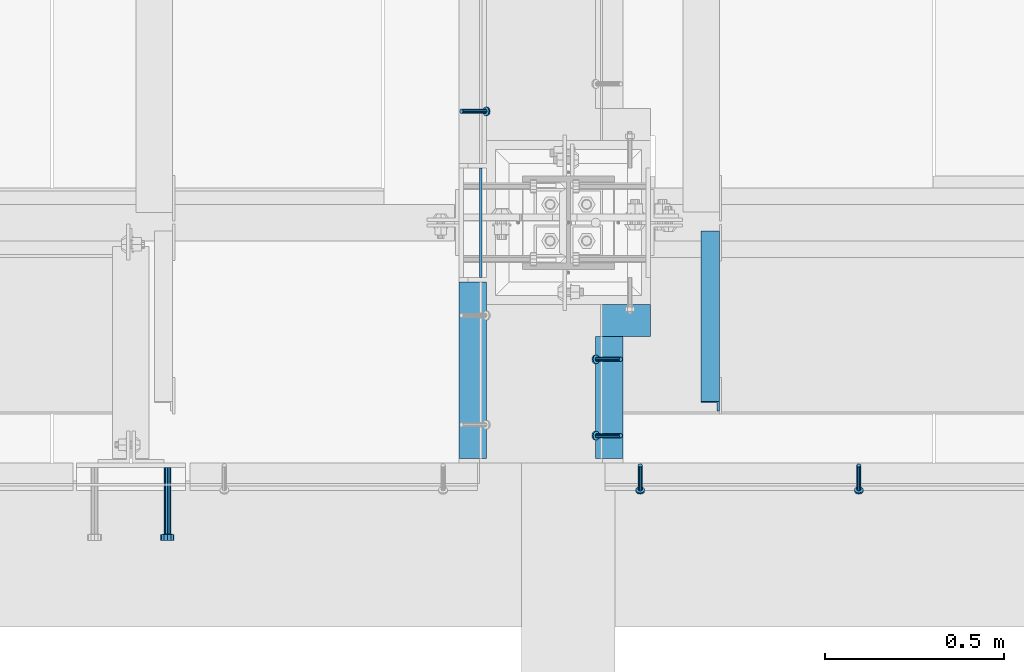
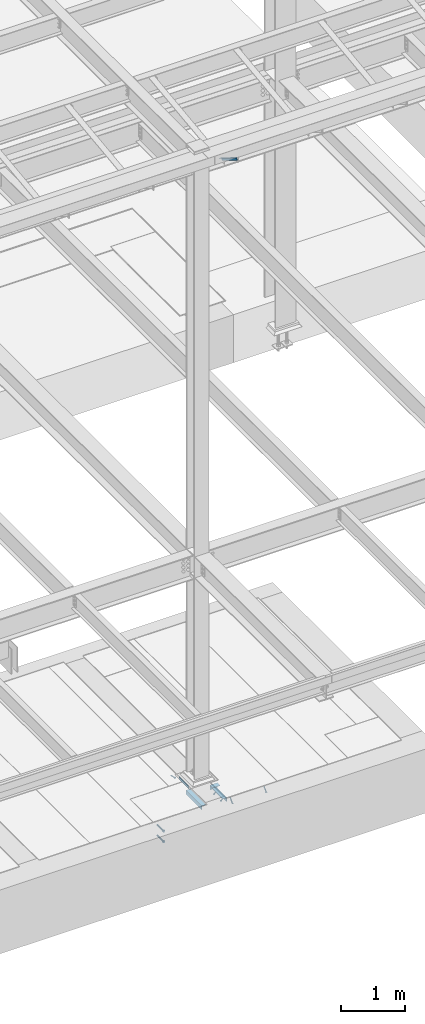
# One storey, part 2050 of 3843: 6 beams, 6 members, 8 elements without a shape of their own.
"""IFC2X3 building model written with IfcOpenShell, lengths in millimetres."""

from ifc_helpers import new_model, si_unit, frame, origin_with_axes, place, context, subcontext, project, spatial, faceted_brep, material, type_object, element, aggregate, save


model = new_model("IFC2X3")

# Units and contexts
model_context = context("Model", 3, precision=1e-05, world=origin_with_axes())
body_context = subcontext(model_context, "Body", "Model", "MODEL_VIEW")
ifc_project = project(units=[si_unit("LENGTHUNIT", "METRE", prefix="MILLI"), si_unit("AREAUNIT", "SQUARE_METRE"), si_unit("VOLUMEUNIT", "CUBIC_METRE"), si_unit("MASSUNIT", "GRAM", prefix="KILO"), si_unit("TIMEUNIT", "SECOND"), si_unit("PLANEANGLEUNIT", "RADIAN"), si_unit("SOLIDANGLEUNIT", "STERADIAN"), si_unit("THERMODYNAMICTEMPERATUREUNIT", "DEGREE_CELSIUS"), si_unit("LUMINOUSINTENSITYUNIT", "LUMEN")], contexts=[model_context])

# Site, building, storey
site_placement = place(None, origin_with_axes())
site = spatial("IfcSite", under=ifc_project, at=site_placement, CompositionType="ELEMENT")
building_placement = place(site_placement, origin_with_axes())
building = spatial("IfcBuilding", under=site, at=building_placement, Name="Undefined", CompositionType="ELEMENT")
storey_placement = place(building_placement, origin_with_axes())
storey = spatial("IfcBuildingStorey", under=building, at=storey_placement, Name="Undefined", CompositionType="ELEMENT", Elevation=0.0)

# Assembly, beam
assembly_1_placement = place(storey_placement, origin_with_axes())
assembly_1 = element("IfcElementAssembly", 1, at=assembly_1_placement, inside=storey, Name="EMBED PLATE", AssemblyPlace="NOTDEFINED", PredefinedType="RIGID_FRAME")
ifc_material_1 = material(Name="STEEL/A36")
beam_type_1 = type_object("IfcBeamType", PredefinedType="NOTDEFINED")
beam_1_placement = place(assembly_1_placement, frame((62391.9249969482, 15151.1, 30454.6), z_axis=(0.0, 0.0, 1.0), x_axis=(0.0, -1.0, 0.0)))
beam_1 = element("IfcBeam", 2, at=beam_1_placement, type_object=beam_type_1, material=ifc_material_1, Name="PLATE", context=body_context, shape_type="Brep", body=[
    faceted_brep([(0.0, 3.17499999999927, -25.4000000000015), (0.0, 3.17499999999927, 25.4000000000015), (304.800000000003, 3.17500000000291, 25.4000000000015), (304.800000000003, 3.17500000000291, -25.4000000000015), (0.0, -3.17499999999927, 25.4000000000015), (304.800000000003, -3.17500000000291, 25.4000000000015), (0.0, -3.17499999999927, -25.4000000000015), (304.800000000003, -3.17500000000291, -25.4000000000015)], [[[0, 1, 2, 3]], [[1, 4, 5, 2]], [[4, 6, 7, 5]], [[6, 0, 3, 7]], [[5, 7, 3, 2]], [[6, 4, 1, 0]]]),
])
aggregate(assembly_1, [beam_1])

# Assembly, members
assembly_2_placement = place(storey_placement, origin_with_axes())
assembly_2 = element("IfcElementAssembly", 3, at=assembly_2_placement, inside=storey, Name="ANGLE", AssemblyPlace="NOTDEFINED", PredefinedType="RIGID_FRAME")
ifc_material_2 = material(Name="STEEL/A108")
member_type_1 = type_object("IfcMemberType", PredefinedType="NOTDEFINED")
member_1_placement = place(assembly_2_placement, frame((62782.4499993064, 14617.7000062051, 30422.8500045777), z_axis=(0.0, -1.0, 0.0), x_axis=(-0.707106781186548, 0.0, -0.707106781186548)))
member_1 = element("IfcMember", 4, at=member_1_placement, type_object=member_type_1, material=ifc_material_2, Name="HEADED STUD ANCHOR", context=body_context, shape_type="Brep", body=[
    faceted_brep([(7.27595761418343e-12, -3.18000006675175, 5.5), (0.0, -5.49999999998363, 3.1800000667572), (94.4879985803855, -5.50000000011278, 3.1800000667572), (94.4879985803782, -3.18000006687362, 5.5), (0.0, -6.3499999046162, 0.0), (94.4879985803855, -6.34999990474535, 0.0), (0.0, -5.49999999998363, -3.1800000667572), (94.4879985803855, -5.50000000011278, -3.1800000667572), (7.27595761418343e-12, -3.18000006675175, -5.5), (94.4879985803782, -3.18000006687362, -5.5), (7.27595761418343e-12, -1.81898940354586e-12, -6.34999990463257), (94.4879985803782, -1.20053300634027e-10, -6.34999990463257), (0.0, 3.18000006675175, -5.5), (94.4879985803709, 3.18000006663351, -5.5), (7.27595761418343e-12, 5.49999999998363, -3.1800000667572), (94.4879985803709, 5.49999999987267, -3.1800000667572), (7.27595761418343e-12, 6.3499999046162, 0.0), (94.4879985803673, 6.34999990450706, 0.0), (7.27595761418343e-12, 5.49999999998363, 3.1800000667572), (94.4879985803709, 5.49999999987267, 3.1800000667572), (0.0, 3.18000006675175, 5.5), (94.4879985803709, 3.18000006663351, 5.5), (7.27595761418343e-12, -1.81898940354586e-12, 6.34999990463257), (94.4879985803782, -1.20053300634027e-10, 6.34999990463257), (96.5199985498621, -10.9899997712273, 6.34999990463257), (96.5199985498548, -6.34000015270249, 10.9899997711182), (96.5199985498621, -12.6999998093743, 0.0), (96.5199985498621, -10.9899997712273, -6.34999990463257), (96.5199985498548, -6.34000015270249, -10.9899997711182), (96.5199985498475, -1.21872290037572e-10, -12.6899995803833), (96.5199985498402, 6.34000015245874, -10.9899997711182), (96.519998549833, 10.9899997709817, -6.34999990463257), (96.519998549833, 12.6999998091305, 0.0), (96.519998549833, 10.9899997709817, 6.34999990463257), (96.5199985498402, 6.34000015245874, 10.9899997711182), (96.5199985498475, -1.21872290037572e-10, 12.6899995803833), (101.599998473539, -10.9899997712328, 6.34999990463257), (101.599998473532, -6.34000015270976, 10.9899997711182), (101.599998473539, -12.6999998093797, 0.0), (101.599998473539, -10.9899997712328, -6.34999990463257), (101.599998473532, -6.34000015270976, -10.9899997711182), (101.599998473524, -1.29148247651756e-10, -12.6899995803833), (101.599998473517, 6.34000015245329, -10.9899997711182), (101.59999847351, 10.9899997709763, -6.34999990463257), (101.599998473503, 12.6999998091196, 0.0), (101.59999847351, 10.9899997709763, 6.34999990463257), (101.599998473517, 6.34000015245329, 10.9899997711182), (101.599998473524, -1.29148247651756e-10, 12.6899995803833)], [[[0, 1, 2, 3]], [[1, 4, 5, 2]], [[4, 6, 7, 5]], [[6, 8, 9, 7]], [[8, 10, 11, 9]], [[10, 12, 13, 11]], [[12, 14, 15, 13]], [[14, 16, 17, 15]], [[16, 18, 19, 17]], [[18, 20, 21, 19]], [[20, 22, 23, 21]], [[22, 0, 3, 23]], [[22, 20, 18, 16, 14, 12, 10, 8, 6, 4, 1, 0]], [[3, 2, 24, 25]], [[2, 5, 26, 24]], [[5, 7, 27, 26]], [[7, 9, 28, 27]], [[9, 11, 29, 28]], [[11, 13, 30, 29]], [[13, 15, 31, 30]], [[15, 17, 32, 31]], [[17, 19, 33, 32]], [[19, 21, 34, 33]], [[21, 23, 35, 34]], [[23, 3, 25, 35]], [[25, 24, 36, 37]], [[24, 26, 38, 36]], [[26, 27, 39, 38]], [[27, 28, 40, 39]], [[28, 29, 41, 40]], [[29, 30, 42, 41]], [[30, 31, 43, 42]], [[31, 32, 44, 43]], [[32, 33, 45, 44]], [[33, 34, 46, 45]], [[34, 35, 47, 46]], [[35, 25, 37, 47]], [[38, 39, 40, 41, 42, 43, 44, 45, 46, 47, 37, 36]]]),
])
member_2_placement = place(assembly_2_placement, frame((62782.4499959028, 14404.9750001016, 30422.8500045777), z_axis=(0.0, -1.0, 0.0), x_axis=(-0.707106781186548, 0.0, -0.707106781186548)))
member_2 = element("IfcMember", 5, at=member_2_placement, type_object=member_type_1, material=ifc_material_2, Name="HEADED STUD ANCHOR", context=body_context, shape_type="Brep", body=[
    faceted_brep([(7.27595761418343e-12, -3.18000006675175, 5.5), (0.0, -5.49999999998363, 3.1800000667572), (94.4879985803855, -5.50000000011278, 3.1800000667572), (94.4879985803782, -3.18000006687362, 5.5), (0.0, -6.3499999046162, 0.0), (94.4879985803855, -6.34999990474535, 0.0), (0.0, -5.49999999998363, -3.1800000667572), (94.4879985803855, -5.50000000011278, -3.1800000667572), (7.27595761418343e-12, -3.18000006675175, -5.5), (94.4879985803782, -3.18000006687362, -5.5), (7.27595761418343e-12, -1.81898940354586e-12, -6.34999990463257), (94.4879985803782, -1.20053300634027e-10, -6.34999990463257), (0.0, 3.18000006675175, -5.5), (94.4879985803709, 3.18000006663351, -5.5), (7.27595761418343e-12, 5.49999999998363, -3.1800000667572), (94.4879985803709, 5.49999999987267, -3.1800000667572), (7.27595761418343e-12, 6.3499999046162, 0.0), (94.4879985803673, 6.34999990450706, 0.0), (7.27595761418343e-12, 5.49999999998363, 3.1800000667572), (94.4879985803709, 5.49999999987267, 3.1800000667572), (0.0, 3.18000006675175, 5.5), (94.4879985803709, 3.18000006663351, 5.5), (7.27595761418343e-12, -1.81898940354586e-12, 6.34999990463257), (94.4879985803782, -1.20053300634027e-10, 6.34999990463257), (96.5199985498621, -10.9899997712273, 6.34999990463257), (96.5199985498548, -6.34000015270249, 10.9899997711182), (96.5199985498621, -12.6999998093743, 0.0), (96.5199985498621, -10.9899997712273, -6.34999990463257), (96.5199985498548, -6.34000015270249, -10.9899997711182), (96.5199985498475, -1.21872290037572e-10, -12.6899995803833), (96.5199985498402, 6.34000015245874, -10.9899997711182), (96.519998549833, 10.9899997709817, -6.34999990463257), (96.519998549833, 12.6999998091305, 0.0), (96.519998549833, 10.9899997709817, 6.34999990463257), (96.5199985498402, 6.34000015245874, 10.9899997711182), (96.5199985498475, -1.21872290037572e-10, 12.6899995803833), (101.599998473539, -10.9899997712328, 6.34999990463257), (101.599998473532, -6.34000015270976, 10.9899997711182), (101.599998473539, -12.6999998093797, 0.0), (101.599998473539, -10.9899997712328, -6.34999990463257), (101.599998473532, -6.34000015270976, -10.9899997711182), (101.599998473524, -1.29148247651756e-10, -12.6899995803833), (101.599998473517, 6.34000015245329, -10.9899997711182), (101.59999847351, 10.9899997709763, -6.34999990463257), (101.599998473503, 12.6999998091196, 0.0), (101.59999847351, 10.9899997709763, 6.34999990463257), (101.599998473517, 6.34000015245329, 10.9899997711182), (101.599998473524, -1.29148247651756e-10, 12.6899995803833)], [[[0, 1, 2, 3]], [[1, 4, 5, 2]], [[4, 6, 7, 5]], [[6, 8, 9, 7]], [[8, 10, 11, 9]], [[10, 12, 13, 11]], [[12, 14, 15, 13]], [[14, 16, 17, 15]], [[16, 18, 19, 17]], [[18, 20, 21, 19]], [[20, 22, 23, 21]], [[22, 0, 3, 23]], [[22, 20, 18, 16, 14, 12, 10, 8, 6, 4, 1, 0]], [[3, 2, 24, 25]], [[2, 5, 26, 24]], [[5, 7, 27, 26]], [[7, 9, 28, 27]], [[9, 11, 29, 28]], [[11, 13, 30, 29]], [[13, 15, 31, 30]], [[15, 17, 32, 31]], [[17, 19, 33, 32]], [[19, 21, 34, 33]], [[21, 23, 35, 34]], [[23, 3, 25, 35]], [[25, 24, 36, 37]], [[24, 26, 38, 36]], [[26, 27, 39, 38]], [[27, 28, 40, 39]], [[28, 29, 41, 40]], [[29, 30, 42, 41]], [[30, 31, 43, 42]], [[31, 32, 44, 43]], [[32, 33, 45, 44]], [[33, 34, 46, 45]], [[34, 35, 47, 46]], [[35, 25, 37, 47]], [[38, 39, 40, 41, 42, 43, 44, 45, 46, 47, 37, 36]]]),
])

# Assembly, member
assembly_3_placement = place(storey_placement, origin_with_axes())
assembly_3 = element("IfcElementAssembly", 6, at=assembly_3_placement, inside=storey, Name="ANGLE", AssemblyPlace="NOTDEFINED", PredefinedType="RIGID_FRAME")
member_3_placement = place(assembly_3_placement, frame((62337.9500063455, 15309.056027729, 30422.8500045777), z_axis=(0.0, 1.0, 0.0), x_axis=(0.707106781186548, 0.0, -0.707106781186548)))
member_3 = element("IfcMember", 7, at=member_3_placement, type_object=member_type_1, material=ifc_material_2, Name="HEADED STUD ANCHOR", context=body_context, shape_type="Brep", body=[
    faceted_brep([(7.27595761418343e-12, -3.18000006675175, 5.5), (0.0, -5.49999999998363, 3.1800000667572), (94.4879985803855, -5.50000000011278, 3.1800000667572), (94.4879985803782, -3.18000006687362, 5.5), (0.0, -6.3499999046162, 0.0), (94.4879985803855, -6.34999990474535, 0.0), (0.0, -5.49999999998363, -3.1800000667572), (94.4879985803855, -5.50000000011278, -3.1800000667572), (7.27595761418343e-12, -3.18000006675175, -5.5), (94.4879985803782, -3.18000006687362, -5.5), (7.27595761418343e-12, -1.81898940354586e-12, -6.34999990463257), (94.4879985803782, -1.20053300634027e-10, -6.34999990463257), (0.0, 3.18000006675175, -5.5), (94.4879985803709, 3.18000006663351, -5.5), (7.27595761418343e-12, 5.49999999998363, -3.1800000667572), (94.4879985803709, 5.49999999987267, -3.1800000667572), (7.27595761418343e-12, 6.3499999046162, 0.0), (94.4879985803673, 6.34999990450706, 0.0), (7.27595761418343e-12, 5.49999999998363, 3.1800000667572), (94.4879985803709, 5.49999999987267, 3.1800000667572), (0.0, 3.18000006675175, 5.5), (94.4879985803709, 3.18000006663351, 5.5), (7.27595761418343e-12, -1.81898940354586e-12, 6.34999990463257), (94.4879985803782, -1.20053300634027e-10, 6.34999990463257), (96.5199985498621, -10.9899997712273, 6.34999990463257), (96.5199985498548, -6.34000015270249, 10.9899997711182), (96.5199985498621, -12.6999998093743, 0.0), (96.5199985498621, -10.9899997712273, -6.34999990463257), (96.5199985498548, -6.34000015270249, -10.9899997711182), (96.5199985498475, -1.21872290037572e-10, -12.6899995803833), (96.5199985498402, 6.34000015245874, -10.9899997711182), (96.519998549833, 10.9899997709817, -6.34999990463257), (96.519998549833, 12.6999998091305, 0.0), (96.519998549833, 10.9899997709817, 6.34999990463257), (96.5199985498402, 6.34000015245874, 10.9899997711182), (96.5199985498475, -1.21872290037572e-10, 12.6899995803833), (101.599998473539, -10.9899997712328, 6.34999990463257), (101.599998473532, -6.34000015270976, 10.9899997711182), (101.599998473539, -12.6999998093797, 0.0), (101.599998473539, -10.9899997712328, -6.34999990463257), (101.599998473532, -6.34000015270976, -10.9899997711182), (101.599998473524, -1.29148247651756e-10, -12.6899995803833), (101.599998473517, 6.34000015245329, -10.9899997711182), (101.59999847351, 10.9899997709763, -6.34999990463257), (101.599998473503, 12.6999998091196, 0.0), (101.59999847351, 10.9899997709763, 6.34999990463257), (101.599998473517, 6.34000015245329, 10.9899997711182), (101.599998473524, -1.29148247651756e-10, 12.6899995803833)], [[[0, 1, 2, 3]], [[1, 4, 5, 2]], [[4, 6, 7, 5]], [[6, 8, 9, 7]], [[8, 10, 11, 9]], [[10, 12, 13, 11]], [[12, 14, 15, 13]], [[14, 16, 17, 15]], [[16, 18, 19, 17]], [[18, 20, 21, 19]], [[20, 22, 23, 21]], [[22, 0, 3, 23]], [[22, 20, 18, 16, 14, 12, 10, 8, 6, 4, 1, 0]], [[3, 2, 24, 25]], [[2, 5, 26, 24]], [[5, 7, 27, 26]], [[7, 9, 28, 27]], [[9, 11, 29, 28]], [[11, 13, 30, 29]], [[13, 15, 31, 30]], [[15, 17, 32, 31]], [[17, 19, 33, 32]], [[19, 21, 34, 33]], [[21, 23, 35, 34]], [[23, 3, 25, 35]], [[25, 24, 36, 37]], [[24, 26, 38, 36]], [[26, 27, 39, 38]], [[27, 28, 40, 39]], [[28, 29, 41, 40]], [[29, 30, 42, 41]], [[30, 31, 43, 42]], [[31, 32, 44, 43]], [[32, 33, 45, 44]], [[33, 34, 46, 45]], [[34, 35, 47, 46]], [[35, 25, 37, 47]], [[38, 39, 40, 41, 42, 43, 44, 45, 46, 47, 37, 36]]]),
])
aggregate(assembly_3, [member_3])

# Assembly, members
assembly_4_placement = place(storey_placement, origin_with_axes())
assembly_4 = element("IfcElementAssembly", 8, at=assembly_4_placement, inside=storey, Name="ANGLE", AssemblyPlace="NOTDEFINED", PredefinedType="RIGID_FRAME")
member_4_placement = place(assembly_4_placement, frame((63446.0249989808, 14322.4249538032, 30422.8500024177), z_axis=(1.0, 0.0, 0.0), x_axis=(0.0, -0.707106781186548, -0.707106781186548)))
member_4 = element("IfcMember", 9, at=member_4_placement, type_object=member_type_1, material=ifc_material_2, Name="HEADED STUD ANCHOR", context=body_context, shape_type="Brep", body=[
    faceted_brep([(7.27595761418343e-12, -3.18000006675175, 5.5), (0.0, -5.49999999998363, 3.1800000667572), (94.4879985803855, -5.50000000011278, 3.1800000667572), (94.4879985803782, -3.18000006687362, 5.5), (0.0, -6.3499999046162, 0.0), (94.4879985803855, -6.34999990474535, 0.0), (0.0, -5.49999999998363, -3.1800000667572), (94.4879985803855, -5.50000000011278, -3.1800000667572), (7.27595761418343e-12, -3.18000006675175, -5.5), (94.4879985803782, -3.18000006687362, -5.5), (7.27595761418343e-12, -1.81898940354586e-12, -6.34999990463257), (94.4879985803782, -1.20053300634027e-10, -6.34999990463257), (0.0, 3.18000006675175, -5.5), (94.4879985803709, 3.18000006663351, -5.5), (7.27595761418343e-12, 5.49999999998363, -3.1800000667572), (94.4879985803709, 5.49999999987267, -3.1800000667572), (7.27595761418343e-12, 6.3499999046162, 0.0), (94.4879985803673, 6.34999990450706, 0.0), (7.27595761418343e-12, 5.49999999998363, 3.1800000667572), (94.4879985803709, 5.49999999987267, 3.1800000667572), (0.0, 3.18000006675175, 5.5), (94.4879985803709, 3.18000006663351, 5.5), (7.27595761418343e-12, -1.81898940354586e-12, 6.34999990463257), (94.4879985803782, -1.20053300634027e-10, 6.34999990463257), (96.5199985498621, -10.9899997712273, 6.34999990463257), (96.5199985498548, -6.34000015270249, 10.9899997711182), (96.5199985498621, -12.6999998093743, 0.0), (96.5199985498621, -10.9899997712273, -6.34999990463257), (96.5199985498548, -6.34000015270249, -10.9899997711182), (96.5199985498475, -1.21872290037572e-10, -12.6899995803833), (96.5199985498402, 6.34000015245874, -10.9899997711182), (96.519998549833, 10.9899997709817, -6.34999990463257), (96.519998549833, 12.6999998091305, 0.0), (96.519998549833, 10.9899997709817, 6.34999990463257), (96.5199985498402, 6.34000015245874, 10.9899997711182), (96.5199985498475, -1.21872290037572e-10, 12.6899995803833), (101.599998473539, -10.9899997712328, 6.34999990463257), (101.599998473532, -6.34000015270976, 10.9899997711182), (101.599998473539, -12.6999998093797, 0.0), (101.599998473539, -10.9899997712328, -6.34999990463257), (101.599998473532, -6.34000015270976, -10.9899997711182), (101.599998473524, -1.29148247651756e-10, -12.6899995803833), (101.599998473517, 6.34000015245329, -10.9899997711182), (101.59999847351, 10.9899997709763, -6.34999990463257), (101.599998473503, 12.6999998091196, 0.0), (101.59999847351, 10.9899997709763, 6.34999990463257), (101.599998473517, 6.34000015245329, 10.9899997711182), (101.599998473524, -1.29148247651756e-10, 12.6899995803833)], [[[0, 1, 2, 3]], [[1, 4, 5, 2]], [[4, 6, 7, 5]], [[6, 8, 9, 7]], [[8, 10, 11, 9]], [[10, 12, 13, 11]], [[12, 14, 15, 13]], [[14, 16, 17, 15]], [[16, 18, 19, 17]], [[18, 20, 21, 19]], [[20, 22, 23, 21]], [[22, 0, 3, 23]], [[22, 20, 18, 16, 14, 12, 10, 8, 6, 4, 1, 0]], [[3, 2, 24, 25]], [[2, 5, 26, 24]], [[5, 7, 27, 26]], [[7, 9, 28, 27]], [[9, 11, 29, 28]], [[11, 13, 30, 29]], [[13, 15, 31, 30]], [[15, 17, 32, 31]], [[17, 19, 33, 32]], [[19, 21, 34, 33]], [[21, 23, 35, 34]], [[23, 3, 25, 35]], [[25, 24, 36, 37]], [[24, 26, 38, 36]], [[26, 27, 39, 38]], [[27, 28, 40, 39]], [[28, 29, 41, 40]], [[29, 30, 42, 41]], [[30, 31, 43, 42]], [[31, 32, 44, 43]], [[32, 33, 45, 44]], [[33, 34, 46, 45]], [[34, 35, 47, 46]], [[35, 25, 37, 47]], [[38, 39, 40, 41, 42, 43, 44, 45, 46, 47, 37, 36]]]),
])
member_5_placement = place(assembly_4_placement, frame((62836.4249989808, 14322.4249538032, 30422.8500024177), z_axis=(1.0, 0.0, 0.0), x_axis=(0.0, -0.707106781186548, -0.707106781186548)))
member_5 = element("IfcMember", 10, at=member_5_placement, type_object=member_type_1, material=ifc_material_2, Name="HEADED STUD ANCHOR", context=body_context, shape_type="Brep", body=[
    faceted_brep([(7.27595761418343e-12, -3.18000006675175, 5.5), (0.0, -5.49999999998363, 3.1800000667572), (94.4879985803855, -5.50000000011278, 3.1800000667572), (94.4879985803782, -3.18000006687362, 5.5), (0.0, -6.3499999046162, 0.0), (94.4879985803855, -6.34999990474535, 0.0), (0.0, -5.49999999998363, -3.1800000667572), (94.4879985803855, -5.50000000011278, -3.1800000667572), (7.27595761418343e-12, -3.18000006675175, -5.5), (94.4879985803782, -3.18000006687362, -5.5), (7.27595761418343e-12, -1.81898940354586e-12, -6.34999990463257), (94.4879985803782, -1.20053300634027e-10, -6.34999990463257), (0.0, 3.18000006675175, -5.5), (94.4879985803709, 3.18000006663351, -5.5), (7.27595761418343e-12, 5.49999999998363, -3.1800000667572), (94.4879985803709, 5.49999999987267, -3.1800000667572), (7.27595761418343e-12, 6.3499999046162, 0.0), (94.4879985803673, 6.34999990450706, 0.0), (7.27595761418343e-12, 5.49999999998363, 3.1800000667572), (94.4879985803709, 5.49999999987267, 3.1800000667572), (0.0, 3.18000006675175, 5.5), (94.4879985803709, 3.18000006663351, 5.5), (7.27595761418343e-12, -1.81898940354586e-12, 6.34999990463257), (94.4879985803782, -1.20053300634027e-10, 6.34999990463257), (96.5199985498621, -10.9899997712273, 6.34999990463257), (96.5199985498548, -6.34000015270249, 10.9899997711182), (96.5199985498621, -12.6999998093743, 0.0), (96.5199985498621, -10.9899997712273, -6.34999990463257), (96.5199985498548, -6.34000015270249, -10.9899997711182), (96.5199985498475, -1.21872290037572e-10, -12.6899995803833), (96.5199985498402, 6.34000015245874, -10.9899997711182), (96.519998549833, 10.9899997709817, -6.34999990463257), (96.519998549833, 12.6999998091305, 0.0), (96.519998549833, 10.9899997709817, 6.34999990463257), (96.5199985498402, 6.34000015245874, 10.9899997711182), (96.5199985498475, -1.21872290037572e-10, 12.6899995803833), (101.599998473539, -10.9899997712328, 6.34999990463257), (101.599998473532, -6.34000015270976, 10.9899997711182), (101.599998473539, -12.6999998093797, 0.0), (101.599998473539, -10.9899997712328, -6.34999990463257), (101.599998473532, -6.34000015270976, -10.9899997711182), (101.599998473524, -1.29148247651756e-10, -12.6899995803833), (101.599998473517, 6.34000015245329, -10.9899997711182), (101.59999847351, 10.9899997709763, -6.34999990463257), (101.599998473503, 12.6999998091196, 0.0), (101.59999847351, 10.9899997709763, 6.34999990463257), (101.599998473517, 6.34000015245329, 10.9899997711182), (101.599998473524, -1.29148247651756e-10, 12.6899995803833)], [[[0, 1, 2, 3]], [[1, 4, 5, 2]], [[4, 6, 7, 5]], [[6, 8, 9, 7]], [[8, 10, 11, 9]], [[10, 12, 13, 11]], [[12, 14, 15, 13]], [[14, 16, 17, 15]], [[16, 18, 19, 17]], [[18, 20, 21, 19]], [[20, 22, 23, 21]], [[22, 0, 3, 23]], [[22, 20, 18, 16, 14, 12, 10, 8, 6, 4, 1, 0]], [[3, 2, 24, 25]], [[2, 5, 26, 24]], [[5, 7, 27, 26]], [[7, 9, 28, 27]], [[9, 11, 29, 28]], [[11, 13, 30, 29]], [[13, 15, 31, 30]], [[15, 17, 32, 31]], [[17, 19, 33, 32]], [[19, 21, 34, 33]], [[21, 23, 35, 34]], [[23, 3, 25, 35]], [[25, 24, 36, 37]], [[24, 26, 38, 36]], [[26, 27, 39, 38]], [[27, 28, 40, 39]], [[28, 29, 41, 40]], [[29, 30, 42, 41]], [[30, 31, 43, 42]], [[31, 32, 44, 43]], [[32, 33, 45, 44]], [[33, 34, 46, 45]], [[34, 35, 47, 46]], [[35, 25, 37, 47]], [[38, 39, 40, 41, 42, 43, 44, 45, 46, 47, 37, 36]]]),
])
aggregate(assembly_4, [member_4, member_5])

# Assembly, beam
assembly_5_placement = place(storey_placement, origin_with_axes())
assembly_5 = element("IfcElementAssembly", 11, at=assembly_5_placement, inside=storey, Name="GRATING", AssemblyPlace="NOTDEFINED", PredefinedType="NOTDEFINED")
beam_type_2 = type_object("IfcBeamType", Name="L3-1/2X3-1/2X1/4", PredefinedType="NOTDEFINED")
beam_2_placement = place(assembly_5_placement, frame((62865.0000416018, 14725.6500002615, 30384.7500045776), z_axis=(0.0, 0.0, -1.0), x_axis=(-1.0, 0.0, 0.0)))
beam_2 = element("IfcBeam", 12, at=beam_2_placement, type_object=beam_type_2, material=ifc_material_1, Name="ANGLE", ObjectType="L3-1/2X3-1/2X1/4", context=body_context, shape_type="Brep", body=[
    faceted_brep([(-3.63797880709171e-12, 44.4499999999971, -44.4500000000007), (-3.63797880709171e-12, 44.4499999999971, 44.4500000000007), (139.699994826158, 44.4499999999043, 44.4500000000007), (139.699994826158, 44.4499999999043, -44.4500000000007), (-3.63797880709171e-11, 38.1000000000149, 44.4500000000007), (139.699994826165, 38.0999999999021, 44.4500000000007), (0.0, 38.0999999999985, -38.0999999999985), (139.699999999997, 38.0999999999985, -38.0999999999985), (4.36557456851006e-11, -44.4500000000226, -38.0999999999985), (139.699994826253, -44.4500000001353, -38.0999999999985), (3.63797880709171e-12, -44.4499999999971, -44.4500000000007), (139.699994826253, -44.4500000001353, -44.4500000000007)], [[[0, 1, 2, 3]], [[1, 4, 5, 2]], [[4, 6, 7, 5]], [[6, 8, 9, 7]], [[8, 10, 11, 9]], [[10, 0, 3, 11]], [[5, 7, 9, 11, 3, 2]], [[10, 8, 6, 4, 1, 0]]]),
])
aggregate(assembly_5, [beam_2])

# Assembly, member
assembly_6_placement = place(storey_placement, origin_with_axes())
assembly_6 = element("IfcElementAssembly", 13, at=assembly_6_placement, inside=storey, Name="ANGLE", AssemblyPlace="NOTDEFINED", PredefinedType="RIGID_FRAME")
ifc_material_3 = material(Name="STEEL/A572-50")
member_type_2 = type_object("IfcMemberType", Name="L2X2X1/4", PredefinedType="NOTDEFINED")
member_6_placement = place(assembly_6_placement, frame((63031.6875, 14962.4615149769, 42136.6100587905), z_axis=(-1.0, 0.0, 0.0), x_axis=(0.0, -0.851012521472712, 0.5251453972917)))
member_6 = element("IfcMember", 14, at=member_6_placement, type_object=member_type_2, material=ifc_material_3, Name="ANGLE", ObjectType="L2X2X1/4", context=body_context, shape_type="Brep", body=[
    faceted_brep([(0.0, 25.4000000000015, -25.4000000000015), (0.0, 25.4000000000015, 25.4000000000015), (558.799999999297, 25.3999999986918, 25.3999999999942), (558.799999999297, 25.3999999986918, -25.3999999999942), (0.0, 19.0500000000029, 25.4000000000015), (558.799999999297, 19.049999998686, 25.3999999999942), (0.0, 19.0500000000029, -19.0499999999993), (558.799999999297, 19.049999998686, -19.0500000000029), (0.0, -25.4000000000015, -19.0499999999993), (558.799999999281, -25.4000000013912, -19.0500000000029), (0.0, -25.4000000000015, -25.4000000000015), (558.799999999281, -25.4000000013912, -25.3999999999942)], [[[0, 1, 2, 3]], [[1, 4, 5, 2]], [[4, 6, 7, 5]], [[6, 8, 9, 7]], [[8, 10, 11, 9]], [[10, 0, 3, 11]], [[5, 7, 9, 11, 3, 2]], [[10, 8, 6, 4, 1, 0]]]),
])
aggregate(assembly_6, [member_6])

# Beam
beam_type_3 = type_object("IfcBeamType", Name="L3X3X1/4", PredefinedType="NOTDEFINED")
beam_3_placement = place(assembly_2_placement, frame((62750.6999948874, 14341.4750006096, 30391.1000045777), z_axis=(0.0, 0.0, -1.0), x_axis=(0.0, 1.0, 0.0)))
beam_3 = element("IfcBeam", 15, at=beam_3_placement, type_object=beam_type_3, material=ifc_material_1, Name="ANGLE", ObjectType="L3X3X1/4", context=body_context, shape_type="Brep", body=[
    faceted_brep([(0.0, 38.0999999999985, -38.0999999999985), (0.0, 38.0999999999985, 38.0999999999985), (339.725016651279, 38.0999999999476, 38.0999999999985), (339.725016651279, 38.0999999999476, -38.0999999999985), (0.0, 31.75, 38.0999999999985), (339.725016651279, 31.7499999999418, 38.0999999999985), (0.0, 31.75, -31.75), (339.725016651279, 31.7499999999418, -31.75), (0.0, -38.0999999999985, -31.75), (339.725016651268, -38.1000000000568, -31.75), (0.0, -38.0999999999985, -38.0999999999985), (339.725016651268, -38.1000000000568, -38.0999999999985)], [[[0, 1, 2, 3]], [[1, 4, 5, 2]], [[4, 6, 7, 5]], [[6, 8, 9, 7]], [[8, 10, 11, 9]], [[10, 0, 3, 11]], [[5, 7, 9, 11, 3, 2]], [[10, 8, 6, 4, 1, 0]]]),
])

aggregate(assembly_2, [member_1, member_2, beam_3])

# Assembly, beam
assembly_7_placement = place(storey_placement, origin_with_axes())
assembly_7 = element("IfcElementAssembly", 16, at=assembly_7_placement, inside=storey, Name="ANGLE", AssemblyPlace="NOTDEFINED", PredefinedType="RIGID_FRAME")
beam_4_placement = place(assembly_7_placement, frame((62369.7000002285, 14833.599990229, 30391.1000045777), z_axis=(0.0, 0.0, -1.0), x_axis=(0.0, -1.0, 0.0)))
beam_4 = element("IfcBeam", 17, at=beam_4_placement, type_object=beam_type_3, material=ifc_material_1, Name="ANGLE", ObjectType="L3X3X1/4", context=body_context, shape_type="Brep", body=[
    faceted_brep([(0.0, 38.0999999999985, -38.0999999999985), (0.0, 38.0999999999985, 38.0999999999985), (492.1249897337, 38.1000000025524, 38.0999999999985), (492.1249897337, 38.1000000025524, -38.0999999999985), (0.0, 31.75, 38.0999999999985), (492.124989733698, 31.7500000025466, 38.0999999999985), (0.0, 31.75, -31.75), (492.124989733698, 31.7500000025466, -31.75), (0.0, -38.0999999999985, -31.75), (492.124989733675, -38.0999999974447, -31.75), (0.0, -38.0999999999985, -38.0999999999985), (492.124989733675, -38.0999999974447, -38.0999999999985)], [[[0, 1, 2, 3]], [[1, 4, 5, 2]], [[4, 6, 7, 5]], [[6, 8, 9, 7]], [[8, 10, 11, 9]], [[10, 0, 3, 11]], [[5, 7, 9, 11, 3, 2]], [[10, 8, 6, 4, 1, 0]]]),
])
aggregate(assembly_7, [beam_4])

# Assembly, beams
assembly_8_placement = place(storey_placement, origin_with_axes())
assembly_8 = element("IfcElementAssembly", 18, at=assembly_8_placement, inside=storey, Name="EMBED PLATE", AssemblyPlace="NOTDEFINED", PredefinedType="RIGID_FRAME")
beam_type_4 = type_object("IfcBeamType", PredefinedType="NOTDEFINED")
beam_5_placement = place(assembly_8_placement, frame((61518.8, 14316.0750030518, 30372.05), z_axis=(1.0, 0.0, 0.0), x_axis=(0.0, -1.0, 0.0)))
beam_5 = element("IfcBeam", 19, at=beam_5_placement, type_object=beam_type_4, material=ifc_material_2, Name="HEADED STUD ANCHOR", context=body_context, shape_type="Brep", body=[
    faceted_brep([(0.0, -9.52000045776367, 0.0), (0.0, -8.25, -4.76000022888184), (184.912000000004, -8.25, -4.76000022888184), (184.912000000004, -9.52000045776367, 0.0), (0.0, -4.76000022888184, -8.25), (184.912000000004, -4.76000022888184, -8.25), (0.0, 0.0, -9.52000045776367), (184.912000000004, 0.0, -9.52000045776367), (0.0, 4.76000022888184, -8.25), (184.912000000004, 4.76000022888184, -8.25), (0.0, 8.25, -4.76000022888184), (184.912000000004, 8.25, -4.76000022888184), (0.0, 9.52000045776367, 0.0), (184.912000000004, 9.52000045776367, 0.0), (0.0, 8.25, 4.76000022888184), (184.912000000004, 8.25, 4.76000022888184), (0.0, 4.76000022888184, 8.25), (184.912000000004, 4.76000022888184, 8.25), (0.0, 0.0, 9.52000045776367), (184.912000000004, 0.0, 9.52000045776367), (0.0, -4.76000022888184, 8.25), (184.912000000004, -4.76000022888184, 8.25), (0.0, -8.25, 4.76000022888184), (184.912000000004, -8.25, 4.76000022888184), (186.944000000003, -16.5, -9.52000045776367), (186.944000000003, -19.0499992370605, 0.0), (186.944000000003, -9.52000045776367, -16.5), (186.944000000003, 0.0, -19.0499992370605), (186.944000000003, 9.52000045776367, -16.5), (186.944000000003, 16.5, -9.52000045776367), (186.944000000003, 19.0499992370605, 0.0), (186.944000000003, 16.5, 9.52000045776367), (186.944000000003, 9.52000045776367, 16.5), (186.944000000003, 0.0, 19.0499992370605), (186.944000000003, -9.52000045776367, 16.5), (186.944000000003, -16.5, 9.52000045776367), (203.199999999997, -16.5, -9.52000045776367), (203.199999999997, -19.0499992370605, 0.0), (203.199999999997, -9.52000045776367, -16.5), (203.199999999997, 0.0, -19.0499992370605), (203.199999999997, 9.52000045776367, -16.5), (203.199999999997, 16.5, -9.52000045776367), (203.199999999997, 19.0499992370605, 0.0), (203.199999999997, 16.5, 9.52000045776367), (203.199999999997, 9.52000045776367, 16.5), (203.199999999997, 0.0, 19.0499992370605), (203.199999999997, -9.52000045776367, 16.5), (203.199999999997, -16.5, 9.52000045776367)], [[[0, 1, 2, 3]], [[1, 4, 5, 2]], [[4, 6, 7, 5]], [[6, 8, 9, 7]], [[8, 10, 11, 9]], [[10, 12, 13, 11]], [[12, 14, 15, 13]], [[14, 16, 17, 15]], [[16, 18, 19, 17]], [[18, 20, 21, 19]], [[20, 22, 23, 21]], [[22, 0, 3, 23]], [[22, 20, 18, 16, 14, 12, 10, 8, 6, 4, 1, 0]], [[3, 2, 24, 25]], [[2, 5, 26, 24]], [[5, 7, 27, 26]], [[7, 9, 28, 27]], [[9, 11, 29, 28]], [[11, 13, 30, 29]], [[13, 15, 31, 30]], [[15, 17, 32, 31]], [[17, 19, 33, 32]], [[19, 21, 34, 33]], [[21, 23, 35, 34]], [[23, 3, 25, 35]], [[25, 24, 36, 37]], [[24, 26, 38, 36]], [[26, 27, 39, 38]], [[27, 28, 40, 39]], [[28, 29, 41, 40]], [[29, 30, 42, 41]], [[30, 31, 43, 42]], [[31, 32, 44, 43]], [[32, 33, 45, 44]], [[33, 34, 46, 45]], [[34, 35, 47, 46]], [[35, 25, 37, 47]], [[38, 39, 40, 41, 42, 43, 44, 45, 46, 47, 37, 36]]]),
])
beam_6_placement = place(assembly_8_placement, frame((61518.8, 14316.0750030518, 30168.85), z_axis=(1.0, 0.0, 0.0), x_axis=(0.0, -1.0, 0.0)))
beam_6 = element("IfcBeam", 20, at=beam_6_placement, type_object=beam_type_4, material=ifc_material_2, Name="HEADED STUD ANCHOR", context=body_context, shape_type="Brep", body=[
    faceted_brep([(0.0, -9.52000045776367, 0.0), (0.0, -8.25, -4.76000022888184), (184.912000000004, -8.25, -4.76000022888184), (184.912000000004, -9.52000045776367, 0.0), (0.0, -4.76000022888184, -8.25), (184.912000000004, -4.76000022888184, -8.25), (0.0, 0.0, -9.52000045776367), (184.912000000004, 0.0, -9.52000045776367), (0.0, 4.76000022888184, -8.25), (184.912000000004, 4.76000022888184, -8.25), (0.0, 8.25, -4.76000022888184), (184.912000000004, 8.25, -4.76000022888184), (0.0, 9.52000045776367, 0.0), (184.912000000004, 9.52000045776367, 0.0), (0.0, 8.25, 4.76000022888184), (184.912000000004, 8.25, 4.76000022888184), (0.0, 4.76000022888184, 8.25), (184.912000000004, 4.76000022888184, 8.25), (0.0, 0.0, 9.52000045776367), (184.912000000004, 0.0, 9.52000045776367), (0.0, -4.76000022888184, 8.25), (184.912000000004, -4.76000022888184, 8.25), (0.0, -8.25, 4.76000022888184), (184.912000000004, -8.25, 4.76000022888184), (186.944000000003, -16.5, -9.52000045776367), (186.944000000003, -19.0499992370605, 0.0), (186.944000000003, -9.52000045776367, -16.5), (186.944000000003, 0.0, -19.0499992370605), (186.944000000003, 9.52000045776367, -16.5), (186.944000000003, 16.5, -9.52000045776367), (186.944000000003, 19.0499992370605, 0.0), (186.944000000003, 16.5, 9.52000045776367), (186.944000000003, 9.52000045776367, 16.5), (186.944000000003, 0.0, 19.0499992370605), (186.944000000003, -9.52000045776367, 16.5), (186.944000000003, -16.5, 9.52000045776367), (203.199999999997, -16.5, -9.52000045776367), (203.199999999997, -19.0499992370605, 0.0), (203.199999999997, -9.52000045776367, -16.5), (203.199999999997, 0.0, -19.0499992370605), (203.199999999997, 9.52000045776367, -16.5), (203.199999999997, 16.5, -9.52000045776367), (203.199999999997, 19.0499992370605, 0.0), (203.199999999997, 16.5, 9.52000045776367), (203.199999999997, 9.52000045776367, 16.5), (203.199999999997, 0.0, 19.0499992370605), (203.199999999997, -9.52000045776367, 16.5), (203.199999999997, -16.5, 9.52000045776367)], [[[0, 1, 2, 3]], [[1, 4, 5, 2]], [[4, 6, 7, 5]], [[6, 8, 9, 7]], [[8, 10, 11, 9]], [[10, 12, 13, 11]], [[12, 14, 15, 13]], [[14, 16, 17, 15]], [[16, 18, 19, 17]], [[18, 20, 21, 19]], [[20, 22, 23, 21]], [[22, 0, 3, 23]], [[22, 20, 18, 16, 14, 12, 10, 8, 6, 4, 1, 0]], [[3, 2, 24, 25]], [[2, 5, 26, 24]], [[5, 7, 27, 26]], [[7, 9, 28, 27]], [[9, 11, 29, 28]], [[11, 13, 30, 29]], [[13, 15, 31, 30]], [[15, 17, 32, 31]], [[17, 19, 33, 32]], [[19, 21, 34, 33]], [[21, 23, 35, 34]], [[23, 3, 25, 35]], [[25, 24, 36, 37]], [[24, 26, 38, 36]], [[26, 27, 39, 38]], [[27, 28, 40, 39]], [[28, 29, 41, 40]], [[29, 30, 42, 41]], [[30, 31, 43, 42]], [[31, 32, 44, 43]], [[32, 33, 45, 44]], [[33, 34, 46, 45]], [[34, 35, 47, 46]], [[35, 25, 37, 47]], [[38, 39, 40, 41, 42, 43, 44, 45, 46, 47, 37, 36]]]),
])
aggregate(assembly_8, [beam_5, beam_6])

save(model, "model.ifc")
